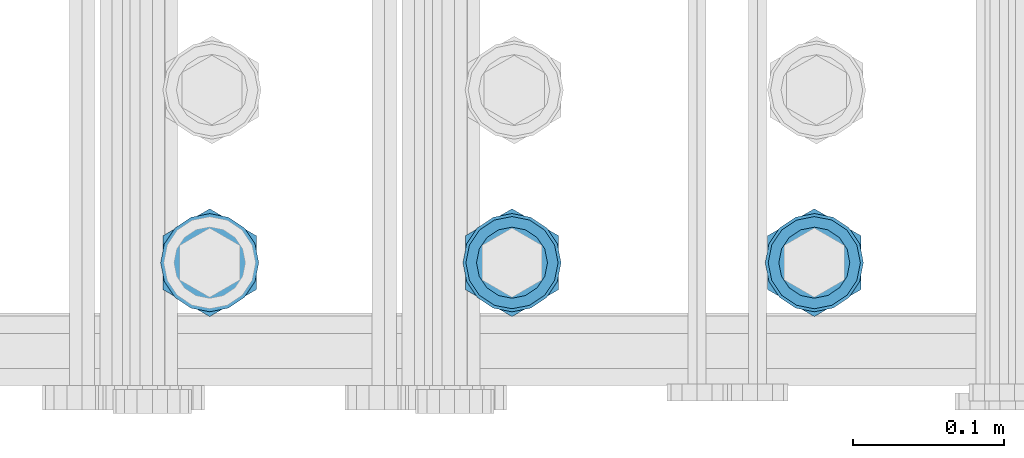
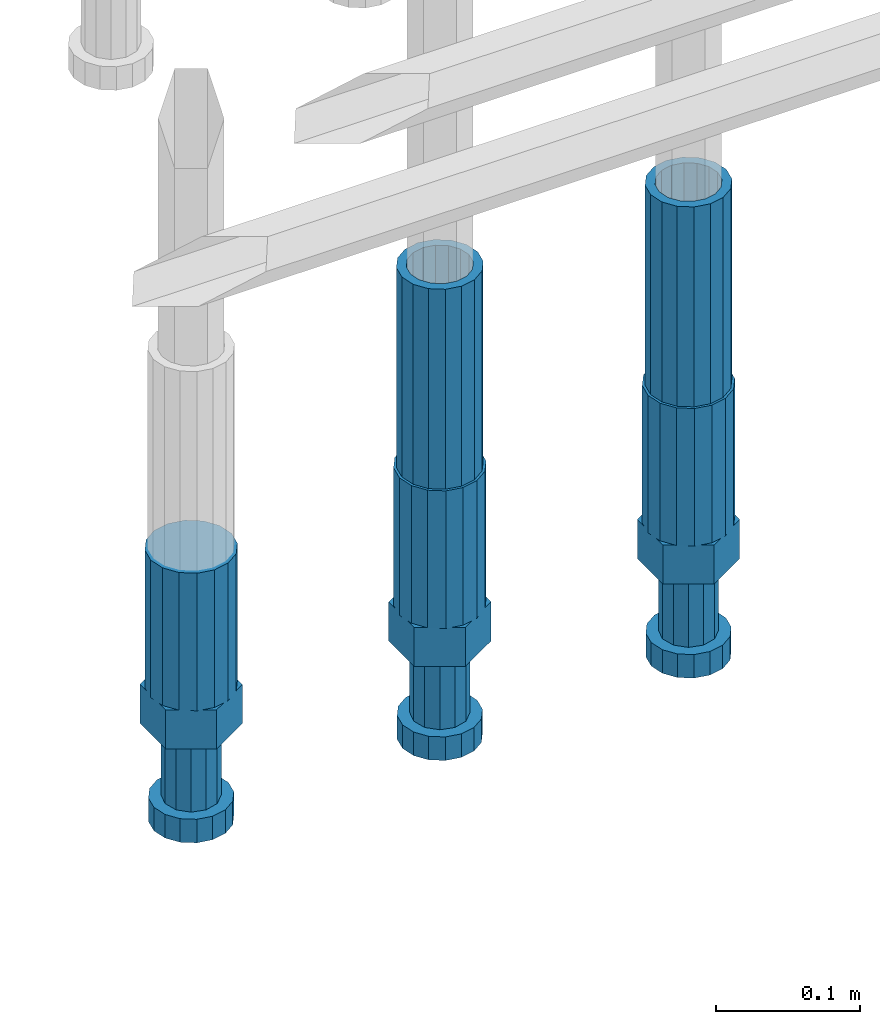
# One storey, part 38 of 177: 5 beams.
"""IFC2X3 building model written with IfcOpenShell, lengths in millimetres."""

from ifc_helpers import new_model, si_unit, frame, origin_with_axes, place, context, subcontext, project, spatial, faceted_brep, material, type_object, element, save


model = new_model("IFC2X3")

# Units and contexts
model_context_1 = context("Model", 3, precision=1e-05, world=origin_with_axes())
model_context_2 = context("Model", 3, precision=1e-05, world=origin_with_axes())
body_context = subcontext(model_context_2, "Body", "Model", "MODEL_VIEW")
ifc_project = project(units=[si_unit("LENGTHUNIT", "METRE", prefix="MILLI"), si_unit("AREAUNIT", "SQUARE_METRE"), si_unit("VOLUMEUNIT", "CUBIC_METRE"), si_unit("MASSUNIT", "GRAM", prefix="KILO"), si_unit("TIMEUNIT", "SECOND"), si_unit("PLANEANGLEUNIT", "RADIAN"), si_unit("SOLIDANGLEUNIT", "STERADIAN"), si_unit("THERMODYNAMICTEMPERATUREUNIT", "DEGREE_CELSIUS"), si_unit("LUMINOUSINTENSITYUNIT", "LUMEN")], contexts=[model_context_1])

# Site, building, storey
site_placement = place(None, origin_with_axes())
site = spatial("IfcSite", under=ifc_project, at=site_placement, CompositionType="ELEMENT")
building_placement = place(site_placement, origin_with_axes())
building = spatial("IfcBuilding", under=site, at=building_placement, Name="Undefined", CompositionType="ELEMENT")
storey_placement = place(building_placement, origin_with_axes())
storey = spatial("IfcBuildingStorey", under=building, at=storey_placement, Name="Undefined", CompositionType="ELEMENT", Elevation=0.0)

# Beams
ifc_material = material(Name="STEEL/S275")
beam_type_1 = type_object("IfcBeamType", PredefinedType="NOTDEFINED")
beam_1_placement = place(storey_placement, frame((2031374.00256279, 6205157.32706445, 18490.9668004289), z_axis=(-1.0, 0.0, 0.0), x_axis=(0.0, 0.0, -1.0)))
element("IfcBeam", 1, at=beam_1_placement, inside=storey, type_object=beam_type_1, material=ifc_material, Name="AG40N", context=body_context, shape_type="Brep", body=[
    faceted_brep([(0.0, -23.5000000001164, -9.31322574615479e-10), (0.0, -21.7111690140155, 8.99306066054851), (170.0, -21.7111690140155, 8.99306066054851), (170.0, -23.5, 0.0), (0.0, -16.6170093578839, 16.6170093575493), (170.0, -16.6170093578839, 16.6170093575493), (0.0, -8.99306066057943, 21.7111690137535), (170.0, -8.99306066057943, 21.7111690137535), (0.0, 1.16415321826935e-10, 23.5), (170.0, 0.0, 23.5), (0.0, 8.99306066057943, 21.7111690137535), (170.0, 8.99306066057943, 21.7111690137535), (0.0, 16.6170093578839, 16.6170093575493), (170.0, 16.6170093578839, 16.6170093575493), (0.0, 21.7111690140155, 8.99306066054851), (170.0, 21.7111690140155, 8.99306066054851), (0.0, 23.5000000001164, -9.31322574615479e-10), (170.0, 23.5, 0.0), (0.0, 21.7111690140155, -8.99306066054851), (170.0, 21.7111690140155, -8.99306066054851), (0.0, 16.6170093578839, -16.6170093575493), (170.0, 16.6170093578839, -16.6170093575493), (0.0, 8.99306066057943, -21.7111690137535), (170.0, 8.99306066057943, -21.7111690137535), (0.0, 1.16415321826935e-10, -23.5000000009313), (170.0, 0.0, -23.5), (0.0, -8.99306066057943, -21.7111690137535), (170.0, -8.99306066057943, -21.7111690137535), (0.0, -16.6170093578839, -16.6170093575493), (170.0, -16.6170093578839, -16.6170093575493), (0.0, -21.7111690140155, -8.99306066054851), (170.0, -21.7111690140155, -8.99306066054851), (0.0, -30.5, 0.0), (0.0, -28.1783257415937, -11.6718446873128), (170.0, -28.1783257415937, -11.6718446873128), (170.0, -30.5, 0.0), (0.0, -21.5667568261888, -21.5667568258941), (170.0, -21.5667568261888, -21.5667568258941), (0.0, -11.6718446871346, -28.1783257415518), (170.0, -11.6718446871346, -28.1783257415518), (0.0, 0.0, -30.5), (170.0, 0.0, -30.5), (0.0, 11.6718446871346, -28.1783257415518), (170.0, 11.6718446871346, -28.1783257415518), (0.0, 21.5667568261888, -21.5667568258941), (170.0, 21.5667568261888, -21.5667568258941), (0.0, 28.1783257415937, -11.6718446873128), (170.0, 28.1783257415937, -11.6718446873128), (0.0, 30.5, 0.0), (170.0, 30.5, 0.0), (0.0, 28.1783257415937, 11.6718446873128), (170.0, 28.1783257415937, 11.6718446873128), (0.0, 21.5667568261888, 21.5667568258941), (170.0, 21.5667568261888, 21.5667568258941), (0.0, 11.6718446871346, 28.1783257415518), (170.0, 11.6718446871346, 28.1783257415518), (0.0, 0.0, 30.5), (170.0, 0.0, 30.5), (0.0, -11.6718446871346, 28.1783257415518), (170.0, -11.6718446871346, 28.1783257415518), (0.0, -21.5667568261888, 21.5667568258941), (170.0, -21.5667568261888, 21.5667568258941), (0.0, -28.1783257415937, 11.6718446873128), (170.0, -28.1783257415937, 11.6718446873128)], [[[0, 1, 2, 3]], [[1, 4, 5, 2]], [[4, 6, 7, 5]], [[6, 8, 9, 7]], [[8, 10, 11, 9]], [[10, 12, 13, 11]], [[12, 14, 15, 13]], [[14, 16, 17, 15]], [[16, 18, 19, 17]], [[18, 20, 21, 19]], [[20, 22, 23, 21]], [[22, 24, 25, 23]], [[24, 26, 27, 25]], [[26, 28, 29, 27]], [[28, 30, 31, 29]], [[30, 0, 3, 31]], [[32, 33, 34, 35]], [[33, 36, 37, 34]], [[36, 38, 39, 37]], [[38, 40, 41, 39]], [[40, 42, 43, 41]], [[42, 44, 45, 43]], [[44, 46, 47, 45]], [[46, 48, 49, 47]], [[48, 50, 51, 49]], [[50, 52, 53, 51]], [[52, 54, 55, 53]], [[54, 56, 57, 55]], [[56, 58, 59, 57]], [[58, 60, 61, 59]], [[60, 62, 63, 61]], [[62, 32, 35, 63]], [[37, 39, 41, 43, 45, 47, 49, 51, 53, 55, 57, 59, 61, 63, 35, 34], [5, 7, 9, 11, 13, 15, 17, 19, 21, 23, 25, 27, 29, 31, 3, 2]], [[62, 60, 58, 56, 54, 52, 50, 48, 46, 44, 42, 40, 38, 36, 33, 32], [30, 28, 26, 24, 22, 20, 18, 16, 14, 12, 10, 8, 6, 4, 1, 0]]]),
])
beam_2_placement = place(storey_placement, frame((2031574.00256247, 6205157.33724079, 18490.9668004289), z_axis=(-1.0, 0.0, 0.0), x_axis=(0.0, 0.0, -1.0)))
element("IfcBeam", 2, at=beam_2_placement, inside=storey, type_object=beam_type_1, material=ifc_material, Name="AG40N", context=body_context, shape_type="Brep", body=[
    faceted_brep([(0.0, -23.5000000001164, -9.31322574615479e-10), (0.0, -21.7111690140155, 8.99306066054851), (170.0, -21.7111690140155, 8.99306066054851), (170.0, -23.5, 0.0), (0.0, -16.6170093578839, 16.6170093575493), (170.0, -16.6170093578839, 16.6170093575493), (0.0, -8.99306066057943, 21.7111690137535), (170.0, -8.99306066057943, 21.7111690137535), (0.0, 1.16415321826935e-10, 23.5), (170.0, 0.0, 23.5), (0.0, 8.99306066057943, 21.7111690137535), (170.0, 8.99306066057943, 21.7111690137535), (0.0, 16.6170093578839, 16.6170093575493), (170.0, 16.6170093578839, 16.6170093575493), (0.0, 21.7111690140155, 8.99306066054851), (170.0, 21.7111690140155, 8.99306066054851), (0.0, 23.5000000001164, -9.31322574615479e-10), (170.0, 23.5, 0.0), (0.0, 21.7111690140155, -8.99306066054851), (170.0, 21.7111690140155, -8.99306066054851), (0.0, 16.6170093578839, -16.6170093575493), (170.0, 16.6170093578839, -16.6170093575493), (0.0, 8.99306066057943, -21.7111690137535), (170.0, 8.99306066057943, -21.7111690137535), (0.0, 1.16415321826935e-10, -23.5000000009313), (170.0, 0.0, -23.5), (0.0, -8.99306066057943, -21.7111690137535), (170.0, -8.99306066057943, -21.7111690137535), (0.0, -16.6170093578839, -16.6170093575493), (170.0, -16.6170093578839, -16.6170093575493), (0.0, -21.7111690140155, -8.99306066054851), (170.0, -21.7111690140155, -8.99306066054851), (0.0, -30.5, 0.0), (0.0, -28.1783257415937, -11.6718446873128), (170.0, -28.1783257415937, -11.6718446873128), (170.0, -30.5, 0.0), (0.0, -21.5667568261888, -21.5667568258941), (170.0, -21.5667568261888, -21.5667568258941), (0.0, -11.6718446871346, -28.1783257415518), (170.0, -11.6718446871346, -28.1783257415518), (0.0, 0.0, -30.5), (170.0, 0.0, -30.5), (0.0, 11.6718446871346, -28.1783257415518), (170.0, 11.6718446871346, -28.1783257415518), (0.0, 21.5667568261888, -21.5667568258941), (170.0, 21.5667568261888, -21.5667568258941), (0.0, 28.1783257415937, -11.6718446873128), (170.0, 28.1783257415937, -11.6718446873128), (0.0, 30.5, 0.0), (170.0, 30.5, 0.0), (0.0, 28.1783257415937, 11.6718446873128), (170.0, 28.1783257415937, 11.6718446873128), (0.0, 21.5667568261888, 21.5667568258941), (170.0, 21.5667568261888, 21.5667568258941), (0.0, 11.6718446871346, 28.1783257415518), (170.0, 11.6718446871346, 28.1783257415518), (0.0, 0.0, 30.5), (170.0, 0.0, 30.5), (0.0, -11.6718446871346, 28.1783257415518), (170.0, -11.6718446871346, 28.1783257415518), (0.0, -21.5667568261888, 21.5667568258941), (170.0, -21.5667568261888, 21.5667568258941), (0.0, -28.1783257415937, 11.6718446873128), (170.0, -28.1783257415937, 11.6718446873128)], [[[0, 1, 2, 3]], [[1, 4, 5, 2]], [[4, 6, 7, 5]], [[6, 8, 9, 7]], [[8, 10, 11, 9]], [[10, 12, 13, 11]], [[12, 14, 15, 13]], [[14, 16, 17, 15]], [[16, 18, 19, 17]], [[18, 20, 21, 19]], [[20, 22, 23, 21]], [[22, 24, 25, 23]], [[24, 26, 27, 25]], [[26, 28, 29, 27]], [[28, 30, 31, 29]], [[30, 0, 3, 31]], [[32, 33, 34, 35]], [[33, 36, 37, 34]], [[36, 38, 39, 37]], [[38, 40, 41, 39]], [[40, 42, 43, 41]], [[42, 44, 45, 43]], [[44, 46, 47, 45]], [[46, 48, 49, 47]], [[48, 50, 51, 49]], [[50, 52, 53, 51]], [[52, 54, 55, 53]], [[54, 56, 57, 55]], [[56, 58, 59, 57]], [[58, 60, 61, 59]], [[60, 62, 63, 61]], [[62, 32, 35, 63]], [[37, 39, 41, 43, 45, 47, 49, 51, 53, 55, 57, 59, 61, 63, 35, 34], [5, 7, 9, 11, 13, 15, 17, 19, 21, 23, 25, 27, 29, 31, 3, 2]], [[62, 60, 58, 56, 54, 52, 50, 48, 46, 44, 42, 40, 38, 36, 33, 32], [30, 28, 26, 24, 22, 20, 18, 16, 14, 12, 10, 8, 6, 4, 1, 0]]]),
])
beam_type_2 = type_object("IfcBeamType", Name="ROD65", PredefinedType="NOTDEFINED")
beam_3_placement = place(storey_placement, frame((2031174.00256311, 6205157.31688811, 18320.9668004289), z_axis=(-1.0, 0.0, 0.0), x_axis=(0.0, 0.0, -1.0)))
element("IfcBeam", 3, at=beam_3_placement, inside=storey, type_object=beam_type_2, material=ifc_material, Name="AGB40", ObjectType="ROD65", context=body_context, shape_type="Brep", body=[
    faceted_brep([(117.0, 8.17543110251427, 30.873805644922), (117.0, 17.8250000001863, 30.873805644922), (117.0, 22.0056958701462, 23.6326279877685), (117.0, 12.4372115517035, 30.0260848065373), (117.0, -17.8250000001863, 30.873805644922), (150.200000000186, -17.8250000001863, 30.873805644922), (150.200000000186, 17.8250000001863, 30.873805644922), (117.0, -8.17543110251427, 30.873805644922), (117.0, -12.4372115517035, 30.0260848065373), (117.0, -22.0056958701462, 23.6326279877685), (117.0, -35.6500000003725, 0.0), (150.200000000186, -35.6500000003725, 0.0), (117.0, -30.8443150008097, 8.32369058486074), (117.0, -32.5, 0.0), (117.0, -30.8443150008097, -8.32369058462791), (117.0, -17.8250000001863, -30.873805644922), (150.200000000186, -17.8250000001863, -30.873805644922), (117.0, -22.0056958701462, -23.6326279877685), (117.0, -12.4372115517035, -30.0260848065373), (117.0, -8.17543110251427, -30.873805644922), (117.0, 17.8250000001863, -30.873805644922), (150.200000000186, 17.8250000001863, -30.873805644922), (117.0, 8.17543110251427, -30.873805644922), (117.0, 22.0056958701462, -23.6326279877685), (117.0, 12.4372115517035, -30.0260848065373), (117.0, 35.6500000003725, 0.0), (150.200000000186, 35.6500000003725, 0.0), (117.0, 30.8443150008097, -8.32369058486074), (117.0, 30.8443150008097, 8.32369058462791), (117.0, 32.5, 0.0), (0.0, -22.9809703892097, 22.9809703885621), (0.0, -30.0260848058388, 12.4372115518636), (117.0, -30.0260848067701, 12.4372115519363), (117.0, -22.9809703882784, 22.9809703885112), (-2.3283064365387e-10, 22.9809703892097, -22.9809703885639), (-4.65661287307739e-10, 30.0260848077014, -12.4372115518672), (117.0, 30.0260848067701, -12.4372115519363), (117.0, 22.9809703882784, -22.9809703885112), (-2.3283064365387e-10, -30.0260848067701, -12.4372115518672), (-2.3283064365387e-10, -22.9809703892097, -22.9809703885621), (117.0, -22.9809703882784, -22.9809703885112), (117.0, -30.0260848067701, -12.4372115519363), (-2.3283064365387e-10, -12.4372115507722, 30.0260848066137), (-2.3283064365387e-10, 9.31322574615479e-10, 32.4999999999982), (-2.3283064365387e-10, 12.4372115526348, 30.0260848066137), (0.0, 22.9809703892097, 22.9809703885621), (-2.3283064365387e-10, 30.0260848077014, 12.4372115518636), (-2.3283064365387e-10, 32.5, 0.0), (-2.3283064365387e-10, 12.4372115526348, -30.0260848066173), (-2.3283064365387e-10, 9.31322574615479e-10, -32.5), (-2.3283064365387e-10, -12.4372115517035, -30.0260848066173), (-4.65661287307739e-10, -32.4999999990687, -1.81898940354586e-12), (117.0, 22.9809703882784, 22.9809703885112), (117.0, 30.0260848067701, 12.4372115519363), (117.0, 0.0, -32.5), (117.0, 0.0, 32.5), (150.200000000186, 10.5, -18.1865334794857), (150.200000000186, 0.0, -21.0), (150.200000000186, -10.5, -18.1865334794857), (150.200000000186, -18.18653347902, -10.5), (150.200000000186, -21.0, 0.0), (150.200000000186, -18.18653347902, 10.5), (150.200000000186, -10.5, 18.1865334794857), (150.200000000186, 0.0, 21.0), (150.200000000186, 10.5, 18.1865334794857), (150.200000000186, 18.18653347902, 10.5), (150.200000000186, 21.0, 0.0), (150.200000000186, 18.18653347902, -10.5), (210.980000000447, -10.5, -18.1865334794857), (210.980000000447, 0.0, -21.0), (210.980000000447, -18.18653347902, -10.5), (210.980000000447, -21.0, 0.0), (210.980000000447, -18.18653347902, 10.5), (210.980000000447, -10.5, 18.1865334794857), (210.980000000447, 0.0, 21.0), (210.980000000447, 10.5, 18.1865334794857), (210.980000000447, 18.18653347902, 10.5), (210.980000000447, 21.0, 0.0), (210.980000000447, 18.18653347902, -10.5), (210.980000000447, 10.5, -18.1865334794857), (211.001368442696, -27.7269937992096, -11.491116326768), (211.003082550167, -21.2238094303757, -21.223815418547), (231.002518367059, -21.2131944671273, -21.2132004550658), (231.000804259587, -27.7163788359612, -11.4805013632867), (211.001368440451, -11.4911085031927, -27.7269970395137), (231.000804257343, -11.4804935399443, -27.7163820760325), (210.996487071217, -0.0106065049767494, -30.0106107392348), (230.995922888109, 8.45827162265778e-06, -29.9999957757536), (210.989181586672, 11.46989420522, -27.7269970329944), (230.988617403564, 11.4805091684684, -27.7163820695132), (210.980564180623, 21.2025914648548, -21.2238154064398), (230.979999997515, 21.2132064281031, -21.2132004429586), (210.971946775022, 27.7057703435421, -11.4911163107026), (230.971382591913, 27.7163853067905, -11.4805013472214), (210.96464129175, 29.9893808094785, -0.0106149562634528), (230.964077108642, 29.9999957727268, 7.21774995326996e-09), (210.959759924415, 27.7057638689876, 11.4698863970116), (230.959195741307, 27.7163788322359, 11.4805013604928), (210.958045816944, 21.2025795001537, 21.2025854887906), (230.957481633835, 21.213194463402, 21.2132004522718), (210.95975992666, 11.4698785729706, 27.7057671097573), (230.959195743551, 11.480493536219, 27.7163820732385), (210.964641295894, -0.010623425245285, 29.9893808094785), (230.964077112785, -8.46199691295624e-06, 29.9999957729597), (210.971946780439, -11.4911241354421, 27.705767103238), (230.97138259733, -11.4805091721937, 27.7163820667192), (210.980564186488, -21.2238213950768, 21.2025854766835), (230.980000003379, -21.2132064318284, 21.2132004401647), (210.989181592089, -27.7270002737641, 11.4698863809463), (230.988617408981, -27.7163853105158, 11.4805013444275), (210.996487075361, -30.0106107397005, -0.0106149734929204), (230.995922892253, -29.9999957764521, -1.00117176771164e-08)], [[[0, 1, 2, 3]], [[4, 5, 6, 1, 0, 7]], [[4, 7, 8, 9]], [[10, 11, 5, 4, 9, 12]], [[10, 12, 13, 14]], [[15, 16, 11, 10, 14, 17]], [[15, 17, 18, 19]], [[20, 21, 16, 15, 19, 22]], [[23, 20, 22, 24]], [[25, 26, 21, 20, 23, 27]], [[28, 25, 27, 29]], [[30, 31, 32, 33]], [[34, 35, 36, 37]], [[38, 39, 40, 41]], [[31, 30, 42, 43, 44, 45, 46, 47, 35, 34, 48, 49, 50, 39, 38, 51]], [[46, 45, 52, 53]], [[29, 47, 46, 53, 28]], [[27, 36, 35, 47, 29]], [[23, 37, 36, 27]], [[24, 48, 34, 37, 23]], [[22, 54, 49, 48, 24]], [[19, 54, 22]], [[18, 50, 49, 54, 19]], [[17, 40, 39, 50, 18]], [[14, 41, 40, 17]], [[13, 51, 38, 41, 14]], [[12, 32, 31, 51, 13]], [[9, 33, 32, 12]], [[8, 42, 30, 33, 9]], [[7, 55, 43, 42, 8]], [[0, 55, 7]], [[3, 44, 43, 55, 0]], [[2, 52, 45, 44, 3]], [[28, 53, 52, 2]], [[1, 6, 26, 25, 28, 2]], [[5, 11, 16, 21, 26, 6], [56, 57, 58, 59, 60, 61, 62, 63, 64, 65, 66, 67]], [[68, 58, 57, 69]], [[70, 59, 58, 68]], [[71, 60, 59, 70]], [[72, 61, 60, 71]], [[73, 62, 61, 72]], [[74, 63, 62, 73]], [[75, 64, 63, 74]], [[76, 65, 64, 75]], [[77, 66, 65, 76]], [[78, 67, 66, 77]], [[79, 56, 67, 78]], [[69, 57, 56, 79]], [[80, 81, 82, 83]], [[81, 84, 85, 82]], [[84, 86, 87, 85]], [[86, 88, 89, 87]], [[88, 90, 91, 89]], [[90, 92, 93, 91]], [[92, 94, 95, 93]], [[94, 96, 97, 95]], [[96, 98, 99, 97]], [[98, 100, 101, 99]], [[100, 102, 103, 101]], [[102, 104, 105, 103]], [[104, 106, 107, 105]], [[106, 108, 109, 107]], [[108, 110, 111, 109]], [[82, 85, 87, 89, 91, 93, 95, 97, 99, 101, 103, 105, 107, 109, 111, 83]], [[110, 80, 83, 111]], [[108, 106, 104, 102, 100, 98, 96, 94, 92, 90, 88, 86, 84, 81, 80, 110], [78, 77, 76, 75, 74, 73, 72, 71, 70, 68, 69, 79]]]),
])
beam_4_placement = place(storey_placement, frame((2031374.00256279, 6205157.32706445, 18320.9668004289), z_axis=(-1.0, 0.0, 0.0), x_axis=(0.0, 0.0, -1.0)))
element("IfcBeam", 4, at=beam_4_placement, inside=storey, type_object=beam_type_2, material=ifc_material, Name="AGB40", ObjectType="ROD65", context=body_context, shape_type="Brep", body=[
    faceted_brep([(117.0, 8.17543110251427, 30.873805644922), (117.0, 17.8250000001863, 30.873805644922), (117.0, 22.0056958701462, 23.6326279877685), (117.0, 12.4372115517035, 30.0260848065373), (117.0, -17.8250000001863, 30.873805644922), (150.200000000186, -17.8250000001863, 30.873805644922), (150.200000000186, 17.8250000001863, 30.873805644922), (117.0, -8.17543110251427, 30.873805644922), (117.0, -12.4372115517035, 30.0260848065373), (117.0, -22.0056958701462, 23.6326279877685), (117.0, -35.6500000003725, 0.0), (150.200000000186, -35.6500000003725, 0.0), (117.0, -30.8443150008097, 8.32369058486074), (117.0, -32.5, 0.0), (117.0, -30.8443150008097, -8.32369058462791), (117.0, -17.8250000001863, -30.873805644922), (150.200000000186, -17.8250000001863, -30.873805644922), (117.0, -22.0056958701462, -23.6326279877685), (117.0, -12.4372115517035, -30.0260848065373), (117.0, -8.17543110251427, -30.873805644922), (117.0, 17.8250000001863, -30.873805644922), (150.200000000186, 17.8250000001863, -30.873805644922), (117.0, 8.17543110251427, -30.873805644922), (117.0, 22.0056958701462, -23.6326279877685), (117.0, 12.4372115517035, -30.0260848065373), (117.0, 35.6500000003725, 0.0), (150.200000000186, 35.6500000003725, 0.0), (117.0, 30.8443150008097, -8.32369058486074), (117.0, 30.8443150008097, 8.32369058462791), (117.0, 32.5, 0.0), (0.0, -22.9809703892097, 22.9809703885621), (0.0, -30.0260848058388, 12.4372115518636), (117.0, -30.0260848067701, 12.4372115519363), (117.0, -22.9809703882784, 22.9809703885112), (-2.3283064365387e-10, 22.9809703892097, -22.9809703885639), (-4.65661287307739e-10, 30.0260848077014, -12.4372115518672), (117.0, 30.0260848067701, -12.4372115519363), (117.0, 22.9809703882784, -22.9809703885112), (-2.3283064365387e-10, -30.0260848067701, -12.4372115518672), (-2.3283064365387e-10, -22.9809703892097, -22.9809703885621), (117.0, -22.9809703882784, -22.9809703885112), (117.0, -30.0260848067701, -12.4372115519363), (-2.3283064365387e-10, -12.4372115507722, 30.0260848066137), (-2.3283064365387e-10, 9.31322574615479e-10, 32.4999999999982), (-2.3283064365387e-10, 12.4372115526348, 30.0260848066137), (0.0, 22.9809703892097, 22.9809703885621), (-2.3283064365387e-10, 30.0260848077014, 12.4372115518636), (-2.3283064365387e-10, 32.5, 0.0), (-2.3283064365387e-10, 12.4372115526348, -30.0260848066173), (-2.3283064365387e-10, 9.31322574615479e-10, -32.5), (-2.3283064365387e-10, -12.4372115517035, -30.0260848066173), (-4.65661287307739e-10, -32.4999999990687, -1.81898940354586e-12), (117.0, 22.9809703882784, 22.9809703885112), (117.0, 30.0260848067701, 12.4372115519363), (117.0, 0.0, -32.5), (117.0, 0.0, 32.5), (150.200000000186, 10.5, -18.1865334794857), (150.200000000186, 0.0, -21.0), (150.200000000186, -10.5, -18.1865334794857), (150.200000000186, -18.18653347902, -10.5), (150.200000000186, -21.0, 0.0), (150.200000000186, -18.18653347902, 10.5), (150.200000000186, -10.5, 18.1865334794857), (150.200000000186, 0.0, 21.0), (150.200000000186, 10.5, 18.1865334794857), (150.200000000186, 18.18653347902, 10.5), (150.200000000186, 21.0, 0.0), (150.200000000186, 18.18653347902, -10.5), (210.980000000447, -10.5, -18.1865334794857), (210.980000000447, 0.0, -21.0), (210.980000000447, -18.18653347902, -10.5), (210.980000000447, -21.0, 0.0), (210.980000000447, -18.18653347902, 10.5), (210.980000000447, -10.5, 18.1865334794857), (210.980000000447, 0.0, 21.0), (210.980000000447, 10.5, 18.1865334794857), (210.980000000447, 18.18653347902, 10.5), (210.980000000447, 21.0, 0.0), (210.980000000447, 18.18653347902, -10.5), (210.980000000447, 10.5, -18.1865334794857), (211.001368442696, -27.7269937992096, -11.491116326768), (211.003082550167, -21.2238094303757, -21.223815418547), (231.002518367059, -21.2131944671273, -21.2132004550658), (231.000804259587, -27.7163788359612, -11.4805013632867), (211.001368440451, -11.4911085031927, -27.7269970395137), (231.000804257343, -11.4804935399443, -27.7163820760325), (210.996487071217, -0.0106065049767494, -30.0106107392348), (230.995922888109, 8.45827162265778e-06, -29.9999957757536), (210.989181586672, 11.46989420522, -27.7269970329944), (230.988617403564, 11.4805091684684, -27.7163820695132), (210.980564180623, 21.2025914648548, -21.2238154064398), (230.979999997515, 21.2132064281031, -21.2132004429586), (210.971946775022, 27.7057703435421, -11.4911163107026), (230.971382591913, 27.7163853067905, -11.4805013472214), (210.96464129175, 29.9893808094785, -0.0106149562634528), (230.964077108642, 29.9999957727268, 7.21774995326996e-09), (210.959759924415, 27.7057638689876, 11.4698863970116), (230.959195741307, 27.7163788322359, 11.4805013604928), (210.958045816944, 21.2025795001537, 21.2025854887906), (230.957481633835, 21.213194463402, 21.2132004522718), (210.95975992666, 11.4698785729706, 27.7057671097573), (230.959195743551, 11.480493536219, 27.7163820732385), (210.964641295894, -0.010623425245285, 29.9893808094785), (230.964077112785, -8.46199691295624e-06, 29.9999957729597), (210.971946780439, -11.4911241354421, 27.705767103238), (230.97138259733, -11.4805091721937, 27.7163820667192), (210.980564186488, -21.2238213950768, 21.2025854766835), (230.980000003379, -21.2132064318284, 21.2132004401647), (210.989181592089, -27.7270002737641, 11.4698863809463), (230.988617408981, -27.7163853105158, 11.4805013444275), (210.996487075361, -30.0106107397005, -0.0106149734929204), (230.995922892253, -29.9999957764521, -1.00117176771164e-08)], [[[0, 1, 2, 3]], [[4, 5, 6, 1, 0, 7]], [[4, 7, 8, 9]], [[10, 11, 5, 4, 9, 12]], [[10, 12, 13, 14]], [[15, 16, 11, 10, 14, 17]], [[15, 17, 18, 19]], [[20, 21, 16, 15, 19, 22]], [[23, 20, 22, 24]], [[25, 26, 21, 20, 23, 27]], [[28, 25, 27, 29]], [[30, 31, 32, 33]], [[34, 35, 36, 37]], [[38, 39, 40, 41]], [[31, 30, 42, 43, 44, 45, 46, 47, 35, 34, 48, 49, 50, 39, 38, 51]], [[46, 45, 52, 53]], [[29, 47, 46, 53, 28]], [[27, 36, 35, 47, 29]], [[23, 37, 36, 27]], [[24, 48, 34, 37, 23]], [[22, 54, 49, 48, 24]], [[19, 54, 22]], [[18, 50, 49, 54, 19]], [[17, 40, 39, 50, 18]], [[14, 41, 40, 17]], [[13, 51, 38, 41, 14]], [[12, 32, 31, 51, 13]], [[9, 33, 32, 12]], [[8, 42, 30, 33, 9]], [[7, 55, 43, 42, 8]], [[0, 55, 7]], [[3, 44, 43, 55, 0]], [[2, 52, 45, 44, 3]], [[28, 53, 52, 2]], [[1, 6, 26, 25, 28, 2]], [[5, 11, 16, 21, 26, 6], [56, 57, 58, 59, 60, 61, 62, 63, 64, 65, 66, 67]], [[68, 58, 57, 69]], [[70, 59, 58, 68]], [[71, 60, 59, 70]], [[72, 61, 60, 71]], [[73, 62, 61, 72]], [[74, 63, 62, 73]], [[75, 64, 63, 74]], [[76, 65, 64, 75]], [[77, 66, 65, 76]], [[78, 67, 66, 77]], [[79, 56, 67, 78]], [[69, 57, 56, 79]], [[80, 81, 82, 83]], [[81, 84, 85, 82]], [[84, 86, 87, 85]], [[86, 88, 89, 87]], [[88, 90, 91, 89]], [[90, 92, 93, 91]], [[92, 94, 95, 93]], [[94, 96, 97, 95]], [[96, 98, 99, 97]], [[98, 100, 101, 99]], [[100, 102, 103, 101]], [[102, 104, 105, 103]], [[104, 106, 107, 105]], [[106, 108, 109, 107]], [[108, 110, 111, 109]], [[82, 85, 87, 89, 91, 93, 95, 97, 99, 101, 103, 105, 107, 109, 111, 83]], [[110, 80, 83, 111]], [[108, 106, 104, 102, 100, 98, 96, 94, 92, 90, 88, 86, 84, 81, 80, 110], [78, 77, 76, 75, 74, 73, 72, 71, 70, 68, 69, 79]]]),
])
beam_5_placement = place(storey_placement, frame((2031574.00256247, 6205157.33724079, 18320.9668004289), z_axis=(-1.0, 0.0, 0.0), x_axis=(0.0, 0.0, -1.0)))
element("IfcBeam", 5, at=beam_5_placement, inside=storey, type_object=beam_type_2, material=ifc_material, Name="AGB40", ObjectType="ROD65", context=body_context, shape_type="Brep", body=[
    faceted_brep([(117.0, 8.17543110251427, 30.873805644922), (117.0, 17.8250000001863, 30.873805644922), (117.0, 22.0056958701462, 23.6326279877685), (117.0, 12.4372115517035, 30.0260848065373), (117.0, -17.8250000001863, 30.873805644922), (150.200000000186, -17.8250000001863, 30.873805644922), (150.200000000186, 17.8250000001863, 30.873805644922), (117.0, -8.17543110251427, 30.873805644922), (117.0, -12.4372115517035, 30.0260848065373), (117.0, -22.0056958701462, 23.6326279877685), (117.0, -35.6500000003725, 0.0), (150.200000000186, -35.6500000003725, 0.0), (117.0, -30.8443150008097, 8.32369058486074), (117.0, -32.5, 0.0), (117.0, -30.8443150008097, -8.32369058462791), (117.0, -17.8250000001863, -30.873805644922), (150.200000000186, -17.8250000001863, -30.873805644922), (117.0, -22.0056958701462, -23.6326279877685), (117.0, -12.4372115517035, -30.0260848065373), (117.0, -8.17543110251427, -30.873805644922), (117.0, 17.8250000001863, -30.873805644922), (150.200000000186, 17.8250000001863, -30.873805644922), (117.0, 8.17543110251427, -30.873805644922), (117.0, 22.0056958701462, -23.6326279877685), (117.0, 12.4372115517035, -30.0260848065373), (117.0, 35.6500000003725, 0.0), (150.200000000186, 35.6500000003725, 0.0), (117.0, 30.8443150008097, -8.32369058486074), (117.0, 30.8443150008097, 8.32369058462791), (117.0, 32.5, 0.0), (0.0, -22.9809703892097, 22.9809703885621), (0.0, -30.0260848058388, 12.4372115518636), (117.0, -30.0260848067701, 12.4372115519363), (117.0, -22.9809703882784, 22.9809703885112), (-2.3283064365387e-10, 22.9809703892097, -22.9809703885639), (-4.65661287307739e-10, 30.0260848077014, -12.4372115518672), (117.0, 30.0260848067701, -12.4372115519363), (117.0, 22.9809703882784, -22.9809703885112), (-2.3283064365387e-10, -30.0260848067701, -12.4372115518672), (-2.3283064365387e-10, -22.9809703892097, -22.9809703885621), (117.0, -22.9809703882784, -22.9809703885112), (117.0, -30.0260848067701, -12.4372115519363), (-2.3283064365387e-10, -12.4372115507722, 30.0260848066137), (-2.3283064365387e-10, 9.31322574615479e-10, 32.4999999999982), (-2.3283064365387e-10, 12.4372115526348, 30.0260848066137), (0.0, 22.9809703892097, 22.9809703885621), (-2.3283064365387e-10, 30.0260848077014, 12.4372115518636), (-2.3283064365387e-10, 32.5, 0.0), (-2.3283064365387e-10, 12.4372115526348, -30.0260848066173), (-2.3283064365387e-10, 9.31322574615479e-10, -32.5), (-2.3283064365387e-10, -12.4372115517035, -30.0260848066173), (-4.65661287307739e-10, -32.4999999990687, -1.81898940354586e-12), (117.0, 22.9809703882784, 22.9809703885112), (117.0, 30.0260848067701, 12.4372115519363), (117.0, 0.0, -32.5), (117.0, 0.0, 32.5), (150.200000000186, 10.5, -18.1865334794857), (150.200000000186, 0.0, -21.0), (150.200000000186, -10.5, -18.1865334794857), (150.200000000186, -18.18653347902, -10.5), (150.200000000186, -21.0, 0.0), (150.200000000186, -18.18653347902, 10.5), (150.200000000186, -10.5, 18.1865334794857), (150.200000000186, 0.0, 21.0), (150.200000000186, 10.5, 18.1865334794857), (150.200000000186, 18.18653347902, 10.5), (150.200000000186, 21.0, 0.0), (150.200000000186, 18.18653347902, -10.5), (210.980000000447, -10.5, -18.1865334794857), (210.980000000447, 0.0, -21.0), (210.980000000447, -18.18653347902, -10.5), (210.980000000447, -21.0, 0.0), (210.980000000447, -18.18653347902, 10.5), (210.980000000447, -10.5, 18.1865334794857), (210.980000000447, 0.0, 21.0), (210.980000000447, 10.5, 18.1865334794857), (210.980000000447, 18.18653347902, 10.5), (210.980000000447, 21.0, 0.0), (210.980000000447, 18.18653347902, -10.5), (210.980000000447, 10.5, -18.1865334794857), (211.001368442696, -27.7269937992096, -11.491116326768), (211.003082550167, -21.2238094303757, -21.223815418547), (231.002518367059, -21.2131944671273, -21.2132004550658), (231.000804259587, -27.7163788359612, -11.4805013632867), (211.001368440451, -11.4911085031927, -27.7269970395137), (231.000804257343, -11.4804935399443, -27.7163820760325), (210.996487071217, -0.0106065049767494, -30.0106107392348), (230.995922888109, 8.45827162265778e-06, -29.9999957757536), (210.989181586672, 11.46989420522, -27.7269970329944), (230.988617403564, 11.4805091684684, -27.7163820695132), (210.980564180623, 21.2025914648548, -21.2238154064398), (230.979999997515, 21.2132064281031, -21.2132004429586), (210.971946775022, 27.7057703435421, -11.4911163107026), (230.971382591913, 27.7163853067905, -11.4805013472214), (210.96464129175, 29.9893808094785, -0.0106149562634528), (230.964077108642, 29.9999957727268, 7.21774995326996e-09), (210.959759924415, 27.7057638689876, 11.4698863970116), (230.959195741307, 27.7163788322359, 11.4805013604928), (210.958045816944, 21.2025795001537, 21.2025854887906), (230.957481633835, 21.213194463402, 21.2132004522718), (210.95975992666, 11.4698785729706, 27.7057671097573), (230.959195743551, 11.480493536219, 27.7163820732385), (210.964641295894, -0.010623425245285, 29.9893808094785), (230.964077112785, -8.46199691295624e-06, 29.9999957729597), (210.971946780439, -11.4911241354421, 27.705767103238), (230.97138259733, -11.4805091721937, 27.7163820667192), (210.980564186488, -21.2238213950768, 21.2025854766835), (230.980000003379, -21.2132064318284, 21.2132004401647), (210.989181592089, -27.7270002737641, 11.4698863809463), (230.988617408981, -27.7163853105158, 11.4805013444275), (210.996487075361, -30.0106107397005, -0.0106149734929204), (230.995922892253, -29.9999957764521, -1.00117176771164e-08)], [[[0, 1, 2, 3]], [[4, 5, 6, 1, 0, 7]], [[4, 7, 8, 9]], [[10, 11, 5, 4, 9, 12]], [[10, 12, 13, 14]], [[15, 16, 11, 10, 14, 17]], [[15, 17, 18, 19]], [[20, 21, 16, 15, 19, 22]], [[23, 20, 22, 24]], [[25, 26, 21, 20, 23, 27]], [[28, 25, 27, 29]], [[30, 31, 32, 33]], [[34, 35, 36, 37]], [[38, 39, 40, 41]], [[31, 30, 42, 43, 44, 45, 46, 47, 35, 34, 48, 49, 50, 39, 38, 51]], [[46, 45, 52, 53]], [[29, 47, 46, 53, 28]], [[27, 36, 35, 47, 29]], [[23, 37, 36, 27]], [[24, 48, 34, 37, 23]], [[22, 54, 49, 48, 24]], [[19, 54, 22]], [[18, 50, 49, 54, 19]], [[17, 40, 39, 50, 18]], [[14, 41, 40, 17]], [[13, 51, 38, 41, 14]], [[12, 32, 31, 51, 13]], [[9, 33, 32, 12]], [[8, 42, 30, 33, 9]], [[7, 55, 43, 42, 8]], [[0, 55, 7]], [[3, 44, 43, 55, 0]], [[2, 52, 45, 44, 3]], [[28, 53, 52, 2]], [[1, 6, 26, 25, 28, 2]], [[5, 11, 16, 21, 26, 6], [56, 57, 58, 59, 60, 61, 62, 63, 64, 65, 66, 67]], [[68, 58, 57, 69]], [[70, 59, 58, 68]], [[71, 60, 59, 70]], [[72, 61, 60, 71]], [[73, 62, 61, 72]], [[74, 63, 62, 73]], [[75, 64, 63, 74]], [[76, 65, 64, 75]], [[77, 66, 65, 76]], [[78, 67, 66, 77]], [[79, 56, 67, 78]], [[69, 57, 56, 79]], [[80, 81, 82, 83]], [[81, 84, 85, 82]], [[84, 86, 87, 85]], [[86, 88, 89, 87]], [[88, 90, 91, 89]], [[90, 92, 93, 91]], [[92, 94, 95, 93]], [[94, 96, 97, 95]], [[96, 98, 99, 97]], [[98, 100, 101, 99]], [[100, 102, 103, 101]], [[102, 104, 105, 103]], [[104, 106, 107, 105]], [[106, 108, 109, 107]], [[108, 110, 111, 109]], [[82, 85, 87, 89, 91, 93, 95, 97, 99, 101, 103, 105, 107, 109, 111, 83]], [[110, 80, 83, 111]], [[108, 106, 104, 102, 100, 98, 96, 94, 92, 90, 88, 86, 84, 81, 80, 110], [78, 77, 76, 75, 74, 73, 72, 71, 70, 68, 69, 79]]]),
])

save(model, "model.ifc")
